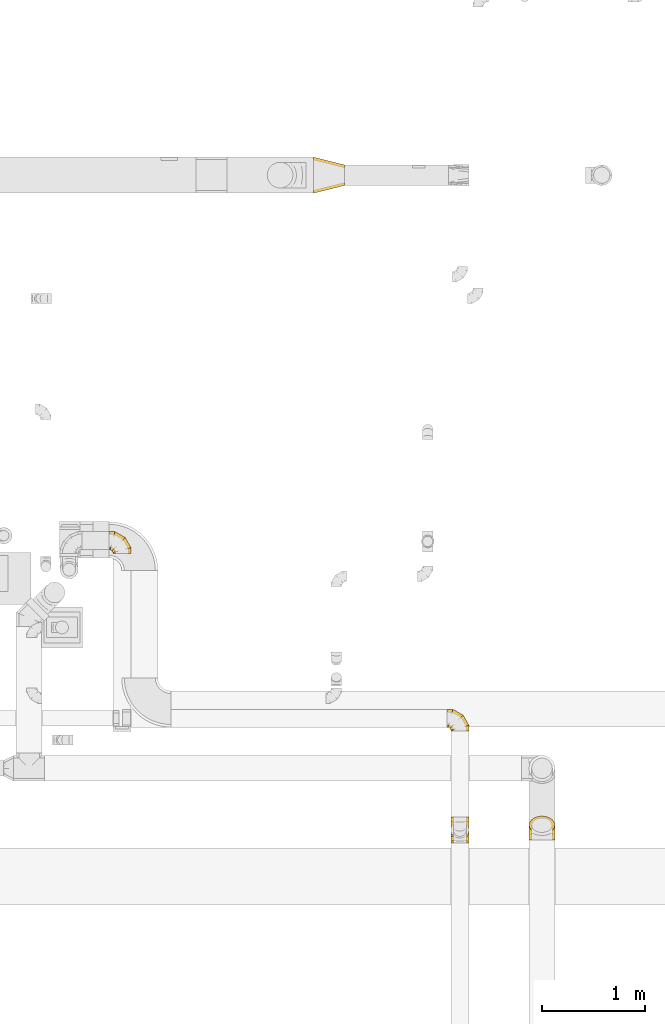
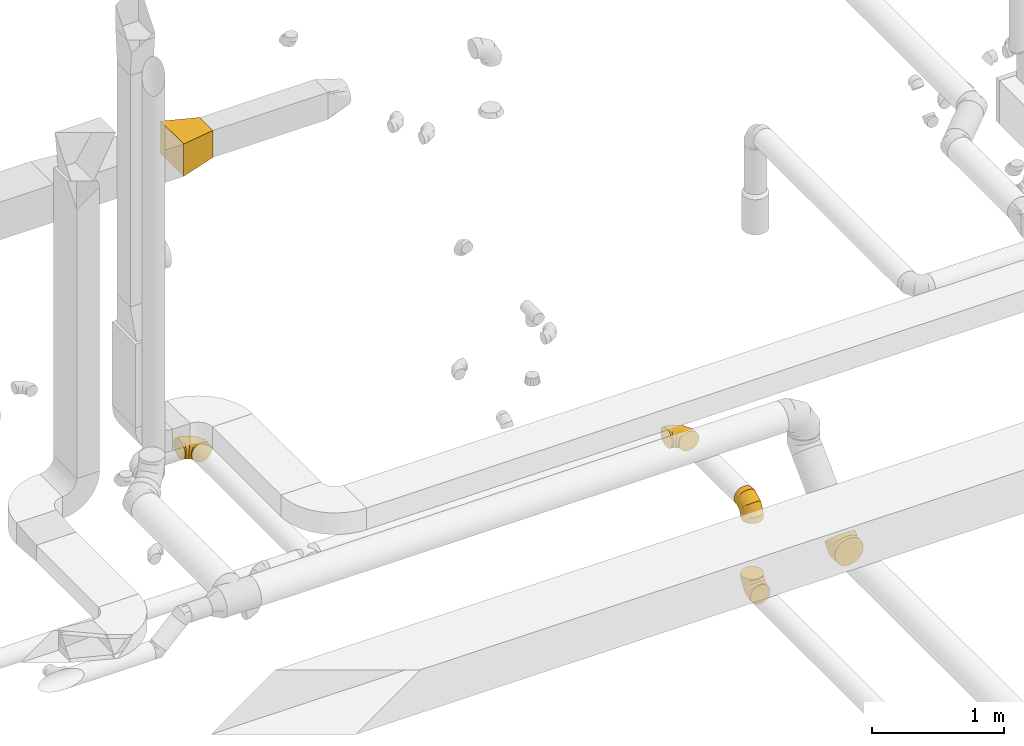
# One storey, part 24 of 97: 6 coverings.
"""IFC2X3 building model written with IfcOpenShell, lengths in millimetres."""

from ifc_helpers import new_model, entity, si_unit, converted_unit, derived_unit, direction, frame, origin, place, context, subcontext, project, spatial, faceted_brep, element, save


model = new_model("IFC2X3")

# Units and contexts
model_context = context("Model", 3, precision=0.01, world=origin(), true_north=direction((6.12303176911189e-17, 1.0)))
body_context = subcontext(model_context, "Body", "Model", "MODEL_VIEW")
ifc_project = project(units=[si_unit("LENGTHUNIT", "METRE", prefix="MILLI"), si_unit("AREAUNIT", "SQUARE_METRE"), si_unit("VOLUMEUNIT", "CUBIC_METRE"), converted_unit("PLANEANGLEUNIT", "DEGREE", entity("IfcRatioMeasure", 0.0174532925199433), si_unit("PLANEANGLEUNIT", "RADIAN"), dimensions=[0, 0, 0, 0, 0, 0, 0]), si_unit("MASSUNIT", "GRAM", prefix="KILO"), derived_unit("MASSDENSITYUNIT", [(si_unit("MASSUNIT", "GRAM", prefix="KILO"), 1), (si_unit("LENGTHUNIT", "METRE"), -3)]), derived_unit("MOMENTOFINERTIAUNIT", [(si_unit("LENGTHUNIT", "METRE"), 4)]), si_unit("TIMEUNIT", "SECOND"), si_unit("FREQUENCYUNIT", "HERTZ"), si_unit("THERMODYNAMICTEMPERATUREUNIT", "DEGREE_CELSIUS"), derived_unit("THERMALTRANSMITTANCEUNIT", [(si_unit("MASSUNIT", "GRAM", prefix="KILO"), 1), (si_unit("THERMODYNAMICTEMPERATUREUNIT", "KELVIN"), -1), (si_unit("TIMEUNIT", "SECOND"), -3)]), derived_unit("VOLUMETRICFLOWRATEUNIT", [(si_unit("LENGTHUNIT", "METRE"), 3), (si_unit("TIMEUNIT", "SECOND"), -1)]), derived_unit("MASSFLOWRATEUNIT", [(si_unit("MASSUNIT", "GRAM", prefix="KILO"), 1), (si_unit("TIMEUNIT", "SECOND"), -1)]), derived_unit("ROTATIONALFREQUENCYUNIT", [(si_unit("TIMEUNIT", "SECOND"), -1)]), si_unit("ELECTRICCURRENTUNIT", "AMPERE"), si_unit("ELECTRICVOLTAGEUNIT", "VOLT"), si_unit("POWERUNIT", "WATT"), si_unit("FORCEUNIT", "NEWTON", prefix="KILO"), si_unit("ILLUMINANCEUNIT", "LUX"), si_unit("LUMINOUSFLUXUNIT", "LUMEN"), si_unit("LUMINOUSINTENSITYUNIT", "CANDELA"), derived_unit("USERDEFINED", [(si_unit("MASSUNIT", "GRAM", prefix="KILO"), -1), (si_unit("LENGTHUNIT", "METRE"), -2), (si_unit("TIMEUNIT", "SECOND"), 3), (si_unit("LUMINOUSFLUXUNIT", "LUMEN"), 1)]), derived_unit("LINEARVELOCITYUNIT", [(si_unit("LENGTHUNIT", "METRE"), 1), (si_unit("TIMEUNIT", "SECOND"), -1)]), si_unit("PRESSUREUNIT", "PASCAL"), derived_unit("USERDEFINED", [(si_unit("LENGTHUNIT", "METRE"), -2), (si_unit("MASSUNIT", "GRAM", prefix="KILO"), 1), (si_unit("TIMEUNIT", "SECOND"), -2)]), derived_unit("LINEARFORCEUNIT", [(si_unit("MASSUNIT", "GRAM", prefix="KILO"), 1), (si_unit("LENGTHUNIT", "METRE"), 1), (si_unit("TIMEUNIT", "SECOND"), -2), (si_unit("LENGTHUNIT", "METRE"), -1)]), derived_unit("PLANARFORCEUNIT", [(si_unit("MASSUNIT", "GRAM", prefix="KILO"), 1), (si_unit("LENGTHUNIT", "METRE"), 1), (si_unit("TIMEUNIT", "SECOND"), -2), (si_unit("LENGTHUNIT", "METRE"), -2)])], contexts=[model_context])

# Site, building, storey
site_placement = place(None, origin())
site = spatial("IfcSite", under=ifc_project, at=site_placement, CompositionType="ELEMENT")
building_placement = place(site_placement, origin())
building = spatial("IfcBuilding", under=site, at=building_placement, CompositionType="ELEMENT")
storey_placement = place(building_placement, frame((0.0, 0.0, -4900.0)))
storey = spatial("IfcBuildingStorey", under=building, at=storey_placement, CompositionType="ELEMENT", Elevation=-4900.0)

# Coverings
covering_1_placement = place(storey_placement, frame((59937.65, 11680.87, 4025.9)))
element("IfcCovering", 1, at=covering_1_placement, inside=storey, PredefinedType="INSULATION", context=body_context, shape_type="Brep", body=[
    faceted_brep([(0.0, 97.96, 172.31), (0.0, 125.0, 176.6), (0.0, 152.04, 172.31), (0.0, 176.43, 159.88), (0.0, 195.79, 140.53), (0.0, 208.22, 116.13), (0.0, 212.5, 89.1), (0.0, 208.22, 62.06), (0.0, 195.79, 37.66), (0.0, 176.43, 18.31), (0.0, 152.04, 5.88), (0.0, 125.0, 1.6), (0.0, 97.96, 5.88), (0.0, 73.57, 18.31), (0.0, 54.21, 37.66), (0.0, 48.0, 49.86), (0.0, 41.78, 62.06), (0.0, 39.64, 75.58), (0.0, 37.5, 89.1), (0.0, 39.64, 102.61), (0.0, 41.78, 116.13), (0.0, 48.0, 128.33), (0.0, 54.21, 140.53), (0.0, 73.57, 159.88), (200.78, 0.0, 45.35), (209.52, 0.0, 66.45), (212.5, 0.0, 89.1), (209.52, 0.0, 111.74), (200.78, 0.0, 132.85), (186.87, 0.0, 150.97), (168.75, 0.0, 164.87), (147.65, 0.0, 173.61), (125.0, 0.0, 176.6), (102.35, 0.0, 173.61), (81.25, 0.0, 164.87), (63.13, 0.0, 150.97), (49.22, 0.0, 132.85), (40.48, 0.0, 111.74), (37.5, 0.0, 89.1), (40.48, 0.0, 66.45), (49.22, 0.0, 45.35), (63.13, 0.0, 27.22), (81.25, 0.0, 13.32), (102.35, 0.0, 4.58), (125.0, 0.0, 1.6), (147.65, 0.0, 4.58), (168.75, 0.0, 13.32), (186.87, 0.0, 27.22), (212.5, 56.94, 89.1), (209.52, 56.14, 111.74), (200.78, 53.8, 132.85), (186.87, 50.07, 150.97), (168.75, 45.22, 164.87), (147.65, 39.56, 173.61), (125.0, 33.49, 176.6), (102.35, 27.43, 173.61), (81.25, 21.77, 164.87), (63.13, 16.92, 150.97), (49.22, 13.19, 132.85), (40.48, 10.85, 111.74), (37.5, 10.05, 89.1), (40.48, 10.85, 66.45), (49.22, 13.19, 45.35), (63.13, 16.92, 27.22), (102.35, 27.43, 4.58), (125.0, 33.49, 1.6), (81.25, 21.77, 13.32), (147.65, 39.56, 4.58), (168.75, 45.22, 13.32), (186.87, 50.07, 27.22), (200.78, 53.8, 45.35), (209.52, 56.14, 66.45), (155.56, 155.56, 89.1), (153.38, 153.38, 111.74), (146.98, 146.98, 132.85), (136.8, 136.8, 150.97), (123.53, 123.53, 164.87), (108.08, 108.08, 173.61), (91.51, 91.51, 176.6), (74.93, 74.93, 173.61), (59.48, 59.48, 164.87), (46.21, 46.21, 150.97), (36.03, 36.03, 132.85), (29.63, 29.63, 111.74), (27.45, 27.45, 89.1), (29.63, 29.63, 66.45), (36.03, 36.03, 45.35), (46.21, 46.21, 27.22), (74.93, 74.93, 4.58), (91.51, 91.51, 1.6), (59.48, 59.48, 13.32), (108.08, 108.08, 4.58), (123.53, 123.53, 13.32), (136.8, 136.8, 27.22), (146.98, 146.98, 45.35), (153.38, 153.38, 66.45), (56.94, 212.5, 89.1), (56.14, 209.52, 111.74), (53.8, 200.78, 132.85), (50.07, 186.87, 150.97), (45.22, 168.75, 164.87), (39.56, 147.65, 173.61), (33.49, 125.0, 176.6), (27.43, 102.35, 173.61), (21.77, 81.25, 164.87), (16.92, 63.13, 150.97), (13.19, 49.22, 132.85), (10.85, 40.48, 111.74), (10.45, 38.99, 100.42), (10.05, 37.5, 89.1), (10.85, 40.48, 66.45), (13.19, 49.22, 45.35), (10.45, 38.99, 77.77), (16.92, 63.13, 27.22), (27.43, 102.35, 4.58), (33.49, 125.0, 1.6), (21.77, 81.25, 13.32), (39.56, 147.65, 4.58), (45.22, 168.75, 13.32), (50.07, 186.87, 27.22), (53.8, 200.78, 45.35), (56.14, 209.52, 66.45)], [[[0, 1, 2, 3, 4, 5, 6, 7, 8, 9, 10, 11, 12, 13, 14, 15, 16, 17, 18, 19, 20, 21, 22, 23]], [[24, 25, 26, 27, 28, 29, 30, 31, 32, 33, 34, 35, 36, 37, 38, 39, 40, 41, 42, 43, 44, 45, 46, 47]], [[26, 48, 49, 27]], [[27, 49, 50, 28]], [[28, 50, 51, 29]], [[30, 52, 53, 31]], [[31, 53, 54, 32]], [[29, 51, 52, 30]], [[55, 56, 34, 33]], [[54, 55, 33, 32]], [[57, 35, 34, 56]], [[58, 59, 37, 36]], [[58, 36, 35, 57]], [[60, 38, 37, 59]], [[61, 62, 40, 39]], [[60, 61, 39, 38]], [[41, 40, 62, 63]], [[64, 65, 44, 43]], [[66, 64, 43, 42]], [[63, 66, 42, 41]], [[46, 45, 67, 68]], [[47, 46, 68, 69]], [[44, 65, 67, 45]], [[25, 24, 70, 71]], [[26, 25, 71, 48]], [[69, 70, 24, 47]], [[49, 48, 72, 73]], [[50, 49, 73, 74]], [[74, 75, 51, 50]], [[52, 51, 75, 76]], [[53, 52, 76, 77]], [[54, 53, 77, 78]], [[79, 80, 56, 55]], [[78, 79, 55, 54]], [[57, 56, 80, 81]], [[82, 83, 59, 58]], [[81, 82, 58, 57]], [[60, 59, 83, 84]], [[85, 86, 62, 61]], [[84, 85, 61, 60]], [[63, 62, 86, 87]], [[88, 89, 65, 64]], [[90, 88, 64, 66]], [[87, 90, 66, 63]], [[67, 65, 89, 91]], [[68, 67, 91, 92]], [[69, 68, 92, 93]], [[71, 70, 94, 95]], [[48, 71, 95, 72]], [[93, 94, 70, 69]], [[73, 72, 96, 97]], [[74, 73, 97, 98]], [[98, 99, 75, 74]], [[76, 75, 99, 100]], [[77, 76, 100, 101]], [[78, 77, 101, 102]], [[103, 104, 80, 79]], [[102, 103, 79, 78]], [[81, 80, 104, 105]], [[106, 107, 83, 82]], [[105, 106, 82, 81]], [[84, 83, 107, 108, 109]], [[110, 111, 86, 85]], [[85, 84, 109, 112, 110]], [[87, 86, 111, 113]], [[114, 115, 89, 88]], [[116, 114, 88, 90]], [[113, 116, 90, 87]], [[91, 89, 115, 117]], [[92, 91, 117, 118]], [[93, 92, 118, 119]], [[95, 94, 120, 121]], [[72, 95, 121, 96]], [[119, 120, 94, 93]], [[97, 6, 5]], [[98, 5, 4]], [[6, 97, 96]], [[97, 5, 98]], [[4, 99, 98]], [[100, 3, 2]], [[101, 2, 1]], [[99, 3, 100]], [[100, 2, 101]], [[1, 102, 101]], [[3, 99, 4]], [[103, 1, 0]], [[104, 0, 23]], [[103, 102, 1]], [[104, 103, 0]], [[23, 105, 104]], [[21, 20, 107]], [[18, 109, 108]], [[107, 20, 19]], [[106, 105, 22]], [[106, 22, 21]], [[107, 19, 108]], [[21, 107, 106]], [[18, 108, 19]], [[22, 105, 23]], [[110, 17, 16]], [[111, 15, 14]], [[18, 112, 109]], [[18, 17, 112]], [[110, 16, 15]], [[110, 15, 111]], [[14, 113, 111]], [[116, 13, 12]], [[114, 12, 11]], [[116, 113, 13]], [[115, 114, 11]], [[116, 12, 114]], [[17, 110, 112]], [[13, 113, 14]], [[117, 11, 10]], [[118, 10, 9]], [[11, 117, 115]], [[117, 10, 118]], [[9, 119, 118]], [[120, 8, 7]], [[121, 7, 6]], [[119, 8, 120]], [[121, 120, 7]], [[96, 121, 6]], [[8, 119, 9]]]),
])
covering_2_placement = place(storey_placement, frame((63249.01, 8911.97, 3990.0)))
element("IfcCovering", 2, at=covering_2_placement, inside=storey, PredefinedType="INSULATION", context=body_context, shape_type="Brep", body=[
    faceted_brep([(172.31, 116.13, 0.0), (176.6, 89.1, 0.0), (172.31, 62.06, 0.0), (159.88, 37.66, 0.0), (140.53, 18.31, 0.0), (116.13, 5.88, 0.0), (89.1, 1.6, 0.0), (62.06, 5.88, 0.0), (37.66, 18.31, 0.0), (18.31, 37.66, 0.0), (5.88, 62.06, 0.0), (1.6, 89.1, 0.0), (5.88, 116.13, 0.0), (18.31, 140.53, 0.0), (37.66, 159.88, 0.0), (49.86, 166.1, 0.0), (62.06, 172.31, 0.0), (75.58, 174.45, 0.0), (89.1, 176.6, 0.0), (102.61, 174.45, 0.0), (116.13, 172.31, 0.0), (128.33, 166.1, 0.0), (140.53, 159.88, 0.0), (159.88, 140.53, 0.0), (45.35, 214.1, 200.78), (66.45, 214.1, 209.52), (89.1, 214.1, 212.5), (111.74, 214.1, 209.52), (132.85, 214.1, 200.78), (150.97, 214.1, 186.87), (164.87, 214.1, 168.75), (173.61, 214.1, 147.65), (176.6, 214.1, 125.0), (173.61, 214.1, 102.35), (164.87, 214.1, 81.25), (150.97, 214.1, 63.13), (132.85, 214.1, 49.22), (111.74, 214.1, 40.48), (89.1, 214.1, 37.5), (66.45, 214.1, 40.48), (45.35, 214.1, 49.22), (27.22, 214.1, 63.13), (13.32, 214.1, 81.25), (4.58, 214.1, 102.35), (1.6, 214.1, 125.0), (4.58, 214.1, 147.65), (13.32, 214.1, 168.75), (27.22, 214.1, 186.87), (89.1, 157.16, 212.5), (111.74, 157.95, 209.52), (132.85, 160.3, 200.78), (150.97, 164.02, 186.87), (164.87, 168.88, 168.75), (173.61, 174.53, 147.65), (176.6, 180.6, 125.0), (173.61, 186.67, 102.35), (164.87, 192.32, 81.25), (150.97, 197.18, 63.13), (132.85, 200.91, 49.22), (111.74, 203.25, 40.48), (89.1, 204.05, 37.5), (66.45, 203.25, 40.48), (45.35, 200.91, 49.22), (27.22, 197.18, 63.13), (4.58, 186.67, 102.35), (1.6, 180.6, 125.0), (13.32, 192.32, 81.25), (4.58, 174.53, 147.65), (13.32, 168.88, 168.75), (27.22, 164.02, 186.87), (45.35, 160.3, 200.78), (66.45, 157.95, 209.52), (89.1, 58.53, 155.56), (111.74, 60.72, 153.38), (132.85, 67.12, 146.98), (150.97, 77.3, 136.8), (164.87, 90.56, 123.53), (173.61, 106.01, 108.08), (176.6, 122.59, 91.51), (173.61, 139.17, 74.93), (164.87, 154.62, 59.48), (150.97, 167.88, 46.21), (132.85, 178.06, 36.03), (111.74, 184.46, 29.63), (89.1, 186.64, 27.45), (66.45, 184.46, 29.63), (45.35, 178.06, 36.03), (27.22, 167.88, 46.21), (4.58, 139.17, 74.93), (1.6, 122.59, 91.51), (13.32, 154.62, 59.48), (4.58, 106.01, 108.08), (13.32, 90.56, 123.53), (27.22, 77.3, 136.8), (45.35, 67.12, 146.98), (66.45, 60.72, 153.38), (89.1, 1.6, 56.94), (111.74, 4.58, 56.14), (132.85, 13.32, 53.8), (150.97, 27.22, 50.07), (164.87, 45.35, 45.22), (173.61, 66.45, 39.56), (176.6, 89.1, 33.49), (173.61, 111.74, 27.43), (164.87, 132.85, 21.77), (150.97, 150.97, 16.92), (132.85, 164.87, 13.19), (111.74, 173.61, 10.85), (100.42, 175.1, 10.45), (89.1, 176.6, 10.05), (66.45, 173.61, 10.85), (45.35, 164.87, 13.19), (77.77, 175.1, 10.45), (27.22, 150.97, 16.92), (4.58, 111.74, 27.43), (1.6, 89.1, 33.49), (13.32, 132.85, 21.77), (4.58, 66.45, 39.56), (13.32, 45.35, 45.22), (27.22, 27.22, 50.07), (45.35, 13.32, 53.8), (66.45, 4.58, 56.14)], [[[0, 1, 2, 3, 4, 5, 6, 7, 8, 9, 10, 11, 12, 13, 14, 15, 16, 17, 18, 19, 20, 21, 22, 23]], [[24, 25, 26, 27, 28, 29, 30, 31, 32, 33, 34, 35, 36, 37, 38, 39, 40, 41, 42, 43, 44, 45, 46, 47]], [[26, 48, 49, 27]], [[27, 49, 50, 28]], [[28, 50, 51, 29]], [[30, 52, 53, 31]], [[31, 53, 54, 32]], [[29, 51, 52, 30]], [[55, 56, 34, 33]], [[54, 55, 33, 32]], [[57, 35, 34, 56]], [[58, 59, 37, 36]], [[58, 36, 35, 57]], [[60, 38, 37, 59]], [[61, 62, 40, 39]], [[60, 61, 39, 38]], [[41, 40, 62, 63]], [[64, 65, 44, 43]], [[66, 64, 43, 42]], [[63, 66, 42, 41]], [[46, 45, 67, 68]], [[47, 46, 68, 69]], [[44, 65, 67, 45]], [[25, 24, 70, 71]], [[26, 25, 71, 48]], [[69, 70, 24, 47]], [[49, 48, 72, 73]], [[50, 49, 73, 74]], [[74, 75, 51, 50]], [[52, 51, 75, 76]], [[53, 52, 76, 77]], [[54, 53, 77, 78]], [[79, 80, 56, 55]], [[78, 79, 55, 54]], [[57, 56, 80, 81]], [[82, 83, 59, 58]], [[81, 82, 58, 57]], [[60, 59, 83, 84]], [[85, 86, 62, 61]], [[84, 85, 61, 60]], [[63, 62, 86, 87]], [[88, 89, 65, 64]], [[90, 88, 64, 66]], [[87, 90, 66, 63]], [[67, 65, 89, 91]], [[68, 67, 91, 92]], [[69, 68, 92, 93]], [[71, 70, 94, 95]], [[48, 71, 95, 72]], [[93, 94, 70, 69]], [[73, 72, 96, 97]], [[74, 73, 97, 98]], [[98, 99, 75, 74]], [[76, 75, 99, 100]], [[77, 76, 100, 101]], [[78, 77, 101, 102]], [[103, 104, 80, 79]], [[102, 103, 79, 78]], [[81, 80, 104, 105]], [[106, 107, 83, 82]], [[105, 106, 82, 81]], [[84, 83, 107, 108, 109]], [[110, 111, 86, 85]], [[85, 84, 109, 112, 110]], [[87, 86, 111, 113]], [[114, 115, 89, 88]], [[116, 114, 88, 90]], [[113, 116, 90, 87]], [[91, 89, 115, 117]], [[92, 91, 117, 118]], [[93, 92, 118, 119]], [[95, 94, 120, 121]], [[72, 95, 121, 96]], [[119, 120, 94, 93]], [[97, 6, 5]], [[98, 5, 4]], [[6, 97, 96]], [[97, 5, 98]], [[4, 99, 98]], [[100, 3, 2]], [[101, 2, 1]], [[99, 3, 100]], [[100, 2, 101]], [[1, 102, 101]], [[3, 99, 4]], [[103, 1, 0]], [[104, 0, 23]], [[103, 102, 1]], [[104, 103, 0]], [[23, 105, 104]], [[21, 20, 107]], [[18, 109, 108]], [[107, 20, 19]], [[106, 105, 22]], [[106, 22, 21]], [[107, 19, 108]], [[21, 107, 106]], [[18, 108, 19]], [[22, 105, 23]], [[110, 17, 16]], [[111, 15, 14]], [[18, 112, 109]], [[18, 17, 112]], [[110, 16, 15]], [[110, 15, 111]], [[14, 113, 111]], [[116, 13, 12]], [[114, 12, 11]], [[116, 113, 13]], [[115, 114, 11]], [[116, 12, 114]], [[17, 110, 112]], [[13, 113, 14]], [[117, 11, 10]], [[118, 10, 9]], [[11, 117, 115]], [[117, 10, 118]], [[9, 119, 118]], [[120, 8, 7]], [[121, 7, 6]], [[119, 8, 120]], [[121, 120, 7]], [[96, 121, 6]], [[8, 119, 9]]]),
])
covering_3_placement = place(storey_placement, frame((63213.11, 9958.58, 4025.9)))
element("IfcCovering", 3, at=covering_3_placement, inside=storey, PredefinedType="INSULATION", context=body_context, shape_type="Brep", body=[
    faceted_brep([(0.0, 97.96, 172.31), (0.0, 125.0, 176.6), (0.0, 152.04, 172.31), (0.0, 176.43, 159.88), (0.0, 195.79, 140.53), (0.0, 208.22, 116.13), (0.0, 212.5, 89.1), (0.0, 208.22, 62.06), (0.0, 195.79, 37.66), (0.0, 176.43, 18.31), (0.0, 152.04, 5.88), (0.0, 125.0, 1.6), (0.0, 97.96, 5.88), (0.0, 73.57, 18.31), (0.0, 54.21, 37.66), (0.0, 48.0, 49.86), (0.0, 41.78, 62.06), (0.0, 39.64, 75.58), (0.0, 37.5, 89.1), (0.0, 39.64, 102.61), (0.0, 41.78, 116.13), (0.0, 48.0, 128.33), (0.0, 54.21, 140.53), (0.0, 73.57, 159.88), (200.78, 0.0, 45.35), (209.52, 0.0, 66.45), (212.5, 0.0, 89.1), (209.52, 0.0, 111.74), (200.78, 0.0, 132.85), (186.87, 0.0, 150.97), (168.75, 0.0, 164.87), (147.65, 0.0, 173.61), (125.0, 0.0, 176.6), (102.35, 0.0, 173.61), (81.25, 0.0, 164.87), (63.13, 0.0, 150.97), (49.22, 0.0, 132.85), (40.48, 0.0, 111.74), (37.5, 0.0, 89.1), (40.48, 0.0, 66.45), (49.22, 0.0, 45.35), (63.13, 0.0, 27.22), (81.25, 0.0, 13.32), (102.35, 0.0, 4.58), (125.0, 0.0, 1.6), (147.65, 0.0, 4.58), (168.75, 0.0, 13.32), (186.87, 0.0, 27.22), (212.5, 56.94, 89.1), (209.52, 56.14, 111.74), (200.78, 53.8, 132.85), (186.87, 50.07, 150.97), (168.75, 45.22, 164.87), (147.65, 39.56, 173.61), (125.0, 33.49, 176.6), (102.35, 27.43, 173.61), (81.25, 21.77, 164.87), (63.13, 16.92, 150.97), (49.22, 13.19, 132.85), (40.48, 10.85, 111.74), (37.5, 10.05, 89.1), (40.48, 10.85, 66.45), (49.22, 13.19, 45.35), (63.13, 16.92, 27.22), (102.35, 27.43, 4.58), (125.0, 33.49, 1.6), (81.25, 21.77, 13.32), (147.65, 39.56, 4.58), (168.75, 45.22, 13.32), (186.87, 50.07, 27.22), (200.78, 53.8, 45.35), (209.52, 56.14, 66.45), (155.56, 155.56, 89.1), (153.38, 153.38, 111.74), (146.98, 146.98, 132.85), (136.8, 136.8, 150.97), (123.53, 123.53, 164.87), (108.08, 108.08, 173.61), (91.51, 91.51, 176.6), (74.93, 74.93, 173.61), (59.48, 59.48, 164.87), (46.21, 46.21, 150.97), (36.03, 36.03, 132.85), (29.63, 29.63, 111.74), (27.45, 27.45, 89.1), (29.63, 29.63, 66.45), (36.03, 36.03, 45.35), (46.21, 46.21, 27.22), (74.93, 74.93, 4.58), (91.51, 91.51, 1.6), (59.48, 59.48, 13.32), (108.08, 108.08, 4.58), (123.53, 123.53, 13.32), (136.8, 136.8, 27.22), (146.98, 146.98, 45.35), (153.38, 153.38, 66.45), (56.94, 212.5, 89.1), (56.14, 209.52, 111.74), (53.8, 200.78, 132.85), (50.07, 186.87, 150.97), (45.22, 168.75, 164.87), (39.56, 147.65, 173.61), (33.49, 125.0, 176.6), (27.43, 102.35, 173.61), (21.77, 81.25, 164.87), (16.92, 63.13, 150.97), (13.19, 49.22, 132.85), (10.85, 40.48, 111.74), (10.45, 38.99, 100.42), (10.05, 37.5, 89.1), (10.85, 40.48, 66.45), (13.19, 49.22, 45.35), (10.45, 38.99, 77.77), (16.92, 63.13, 27.22), (27.43, 102.35, 4.58), (33.49, 125.0, 1.6), (21.77, 81.25, 13.32), (39.56, 147.65, 4.58), (45.22, 168.75, 13.32), (50.07, 186.87, 27.22), (53.8, 200.78, 45.35), (56.14, 209.52, 66.45)], [[[0, 1, 2, 3, 4, 5, 6, 7, 8, 9, 10, 11, 12, 13, 14, 15, 16, 17, 18, 19, 20, 21, 22, 23]], [[24, 25, 26, 27, 28, 29, 30, 31, 32, 33, 34, 35, 36, 37, 38, 39, 40, 41, 42, 43, 44, 45, 46, 47]], [[26, 48, 49, 27]], [[27, 49, 50, 28]], [[28, 50, 51, 29]], [[30, 52, 53, 31]], [[31, 53, 54, 32]], [[29, 51, 52, 30]], [[55, 56, 34, 33]], [[54, 55, 33, 32]], [[57, 35, 34, 56]], [[58, 59, 37, 36]], [[58, 36, 35, 57]], [[60, 38, 37, 59]], [[61, 62, 40, 39]], [[60, 61, 39, 38]], [[41, 40, 62, 63]], [[64, 65, 44, 43]], [[66, 64, 43, 42]], [[63, 66, 42, 41]], [[46, 45, 67, 68]], [[47, 46, 68, 69]], [[44, 65, 67, 45]], [[25, 24, 70, 71]], [[26, 25, 71, 48]], [[69, 70, 24, 47]], [[49, 48, 72, 73]], [[50, 49, 73, 74]], [[74, 75, 51, 50]], [[52, 51, 75, 76]], [[53, 52, 76, 77]], [[54, 53, 77, 78]], [[79, 80, 56, 55]], [[78, 79, 55, 54]], [[57, 56, 80, 81]], [[82, 83, 59, 58]], [[81, 82, 58, 57]], [[60, 59, 83, 84]], [[85, 86, 62, 61]], [[84, 85, 61, 60]], [[63, 62, 86, 87]], [[88, 89, 65, 64]], [[90, 88, 64, 66]], [[87, 90, 66, 63]], [[67, 65, 89, 91]], [[68, 67, 91, 92]], [[69, 68, 92, 93]], [[71, 70, 94, 95]], [[48, 71, 95, 72]], [[93, 94, 70, 69]], [[73, 72, 96, 97]], [[74, 73, 97, 98]], [[98, 99, 75, 74]], [[76, 75, 99, 100]], [[77, 76, 100, 101]], [[78, 77, 101, 102]], [[103, 104, 80, 79]], [[102, 103, 79, 78]], [[81, 80, 104, 105]], [[106, 107, 83, 82]], [[105, 106, 82, 81]], [[84, 83, 107, 108, 109]], [[110, 111, 86, 85]], [[85, 84, 109, 112, 110]], [[87, 86, 111, 113]], [[114, 115, 89, 88]], [[116, 114, 88, 90]], [[113, 116, 90, 87]], [[91, 89, 115, 117]], [[92, 91, 117, 118]], [[93, 92, 118, 119]], [[95, 94, 120, 121]], [[72, 95, 121, 96]], [[119, 120, 94, 93]], [[97, 6, 5]], [[98, 5, 4]], [[6, 97, 96]], [[97, 5, 98]], [[4, 99, 98]], [[100, 3, 2]], [[101, 2, 1]], [[99, 3, 100]], [[100, 2, 101]], [[1, 102, 101]], [[3, 99, 4]], [[103, 1, 0]], [[104, 0, 23]], [[103, 102, 1]], [[104, 103, 0]], [[23, 105, 104]], [[21, 20, 107]], [[18, 109, 108]], [[107, 20, 19]], [[106, 105, 22]], [[106, 22, 21]], [[107, 19, 108]], [[21, 107, 106]], [[18, 108, 19]], [[22, 105, 23]], [[110, 17, 16]], [[111, 15, 14]], [[18, 112, 109]], [[18, 17, 112]], [[110, 16, 15]], [[110, 15, 111]], [[14, 113, 111]], [[116, 13, 12]], [[114, 12, 11]], [[116, 113, 13]], [[115, 114, 11]], [[116, 12, 114]], [[17, 110, 112]], [[13, 113, 14]], [[117, 11, 10]], [[118, 10, 9]], [[11, 117, 115]], [[117, 10, 118]], [[9, 119, 118]], [[120, 8, 7]], [[121, 7, 6]], [[119, 8, 120]], [[121, 120, 7]], [[96, 121, 6]], [[8, 119, 9]]]),
])
covering_4_placement = place(storey_placement, frame((61920.37, 15173.96, 3900.0)))
element("IfcCovering", 4, at=covering_4_placement, inside=storey, PredefinedType="INSULATION", context=body_context, shape_type="Brep", body=[
    faceted_brep([(300.0, 75.0, 275.0), (300.0, 75.0, 25.0), (300.0, 275.0, 25.0), (300.0, 275.0, 275.0), (0.0, 0.0, 300.0), (0.0, 350.0, 300.0), (0.0, 350.0, 0.0), (0.0, 0.0, 0.0)], [[[0, 1, 2, 3]], [[4, 5, 6, 7]], [[4, 7, 1, 0]], [[7, 6, 2, 1]], [[6, 5, 3, 2]], [[5, 4, 0, 3]]]),
])
covering_5_placement = place(storey_placement, frame((63249.01, 8876.07, 3260.9)))
element("IfcCovering", 5, at=covering_5_placement, inside=storey, PredefinedType="INSULATION", context=body_context, shape_type="Brep", body=[
    faceted_brep([(5.88, 0.0, 116.13), (1.6, 0.0, 89.1), (5.88, 0.0, 62.06), (18.31, 0.0, 37.66), (37.66, 0.0, 18.31), (62.06, 0.0, 5.88), (89.1, 0.0, 1.6), (116.13, 0.0, 5.88), (140.53, 0.0, 18.31), (159.88, 0.0, 37.66), (172.31, 0.0, 62.06), (176.6, 0.0, 89.1), (172.31, 0.0, 116.13), (159.88, 0.0, 140.53), (140.53, 0.0, 159.88), (128.33, 0.0, 166.1), (116.13, 0.0, 172.31), (102.61, 0.0, 174.45), (89.1, 0.0, 176.6), (75.58, 0.0, 174.45), (62.06, 0.0, 172.31), (49.86, 0.0, 166.1), (37.66, 0.0, 159.88), (18.31, 0.0, 140.53), (132.85, 200.78, 214.1), (111.74, 209.52, 214.1), (89.1, 212.5, 214.1), (66.45, 209.52, 214.1), (45.35, 200.78, 214.1), (27.22, 186.87, 214.1), (13.32, 168.75, 214.1), (4.58, 147.65, 214.1), (1.6, 125.0, 214.1), (4.58, 102.35, 214.1), (13.32, 81.25, 214.1), (27.22, 63.13, 214.1), (45.35, 49.22, 214.1), (66.45, 40.48, 214.1), (89.1, 37.5, 214.1), (111.74, 40.48, 214.1), (132.85, 49.22, 214.1), (150.97, 63.13, 214.1), (164.87, 81.25, 214.1), (173.61, 102.35, 214.1), (176.6, 125.0, 214.1), (173.61, 147.65, 214.1), (164.87, 168.75, 214.1), (150.97, 186.87, 214.1), (89.1, 212.5, 157.16), (66.45, 209.52, 157.95), (45.35, 200.78, 160.3), (27.22, 186.87, 164.02), (13.32, 168.75, 168.88), (4.58, 147.65, 174.53), (1.6, 125.0, 180.6), (4.58, 102.35, 186.67), (13.32, 81.25, 192.32), (27.22, 63.13, 197.18), (45.35, 49.22, 200.91), (66.45, 40.48, 203.25), (89.1, 37.5, 204.05), (111.74, 40.48, 203.25), (132.85, 49.22, 200.91), (150.97, 63.13, 197.18), (173.61, 102.35, 186.67), (176.6, 125.0, 180.6), (164.87, 81.25, 192.32), (173.61, 147.65, 174.53), (164.87, 168.75, 168.88), (150.97, 186.87, 164.02), (132.85, 200.78, 160.3), (111.74, 209.52, 157.95), (89.1, 155.56, 58.53), (66.45, 153.38, 60.72), (45.35, 146.98, 67.12), (27.22, 136.8, 77.3), (13.32, 123.53, 90.56), (4.58, 108.08, 106.01), (1.6, 91.51, 122.59), (4.58, 74.93, 139.17), (13.32, 59.48, 154.62), (27.22, 46.21, 167.88), (45.35, 36.03, 178.06), (66.45, 29.63, 184.46), (89.1, 27.45, 186.64), (111.74, 29.63, 184.46), (132.85, 36.03, 178.06), (150.97, 46.21, 167.88), (173.61, 74.93, 139.17), (176.6, 91.51, 122.59), (164.87, 59.48, 154.62), (173.61, 108.08, 106.01), (164.87, 123.53, 90.56), (150.97, 136.8, 77.3), (132.85, 146.98, 67.12), (111.74, 153.38, 60.72), (89.1, 56.94, 1.6), (66.45, 56.14, 4.58), (45.35, 53.8, 13.32), (27.22, 50.07, 27.22), (13.32, 45.22, 45.35), (4.58, 39.56, 66.45), (1.6, 33.49, 89.1), (4.58, 27.43, 111.74), (13.32, 21.77, 132.85), (27.22, 16.92, 150.97), (45.35, 13.19, 164.87), (66.45, 10.85, 173.61), (77.77, 10.45, 175.1), (89.1, 10.05, 176.6), (111.74, 10.85, 173.61), (132.85, 13.19, 164.87), (100.42, 10.45, 175.1), (150.97, 16.92, 150.97), (173.61, 27.43, 111.74), (176.6, 33.49, 89.1), (164.87, 21.77, 132.85), (173.61, 39.56, 66.45), (164.87, 45.22, 45.35), (150.97, 50.07, 27.22), (132.85, 53.8, 13.32), (111.74, 56.14, 4.58)], [[[0, 1, 2, 3, 4, 5, 6, 7, 8, 9, 10, 11, 12, 13, 14, 15, 16, 17, 18, 19, 20, 21, 22, 23]], [[24, 25, 26, 27, 28, 29, 30, 31, 32, 33, 34, 35, 36, 37, 38, 39, 40, 41, 42, 43, 44, 45, 46, 47]], [[26, 48, 49, 27]], [[27, 49, 50, 28]], [[28, 50, 51, 29]], [[30, 52, 53, 31]], [[31, 53, 54, 32]], [[29, 51, 52, 30]], [[55, 56, 34, 33]], [[54, 55, 33, 32]], [[57, 35, 34, 56]], [[58, 59, 37, 36]], [[58, 36, 35, 57]], [[60, 38, 37, 59]], [[61, 62, 40, 39]], [[60, 61, 39, 38]], [[41, 40, 62, 63]], [[64, 65, 44, 43]], [[66, 64, 43, 42]], [[63, 66, 42, 41]], [[46, 45, 67, 68]], [[47, 46, 68, 69]], [[44, 65, 67, 45]], [[25, 24, 70, 71]], [[26, 25, 71, 48]], [[69, 70, 24, 47]], [[49, 48, 72, 73]], [[50, 49, 73, 74]], [[74, 75, 51, 50]], [[52, 51, 75, 76]], [[53, 52, 76, 77]], [[54, 53, 77, 78]], [[79, 80, 56, 55]], [[78, 79, 55, 54]], [[57, 56, 80, 81]], [[82, 83, 59, 58]], [[81, 82, 58, 57]], [[60, 59, 83, 84]], [[85, 86, 62, 61]], [[84, 85, 61, 60]], [[63, 62, 86, 87]], [[88, 89, 65, 64]], [[90, 88, 64, 66]], [[87, 90, 66, 63]], [[67, 65, 89, 91]], [[68, 67, 91, 92]], [[69, 68, 92, 93]], [[71, 70, 94, 95]], [[48, 71, 95, 72]], [[93, 94, 70, 69]], [[73, 72, 96, 97]], [[74, 73, 97, 98]], [[98, 99, 75, 74]], [[76, 75, 99, 100]], [[77, 76, 100, 101]], [[78, 77, 101, 102]], [[103, 104, 80, 79]], [[102, 103, 79, 78]], [[81, 80, 104, 105]], [[106, 107, 83, 82]], [[105, 106, 82, 81]], [[84, 83, 107, 108, 109]], [[110, 111, 86, 85]], [[85, 84, 109, 112, 110]], [[87, 86, 111, 113]], [[114, 115, 89, 88]], [[116, 114, 88, 90]], [[113, 116, 90, 87]], [[91, 89, 115, 117]], [[92, 91, 117, 118]], [[93, 92, 118, 119]], [[95, 94, 120, 121]], [[72, 95, 121, 96]], [[119, 120, 94, 93]], [[97, 6, 5]], [[98, 5, 4]], [[6, 97, 96]], [[97, 5, 98]], [[4, 99, 98]], [[100, 3, 2]], [[101, 2, 1]], [[99, 3, 100]], [[100, 2, 101]], [[1, 102, 101]], [[3, 99, 4]], [[103, 1, 0]], [[104, 0, 23]], [[103, 102, 1]], [[104, 103, 0]], [[23, 105, 104]], [[21, 20, 107]], [[18, 109, 108]], [[107, 20, 19]], [[106, 105, 22]], [[106, 22, 21]], [[107, 19, 108]], [[21, 107, 106]], [[18, 108, 19]], [[22, 105, 23]], [[110, 17, 16]], [[111, 15, 14]], [[18, 112, 109]], [[18, 17, 112]], [[110, 16, 15]], [[110, 15, 111]], [[14, 113, 111]], [[116, 13, 12]], [[114, 12, 11]], [[116, 113, 13]], [[115, 114, 11]], [[116, 12, 114]], [[17, 110, 112]], [[13, 113, 14]], [[117, 11, 10]], [[118, 10, 9]], [[11, 117, 115]], [[117, 10, 118]], [[9, 119, 118]], [[120, 8, 7]], [[121, 7, 6]], [[119, 8, 120]], [[121, 120, 7]], [[96, 121, 6]], [[8, 119, 9]]]),
])
covering_6_placement = place(storey_placement, frame((64007.19, 8906.14, 3323.4)))
element("IfcCovering", 6, at=covering_6_placement, inside=storey, PredefinedType="INSULATION", context=body_context, shape_type="Brep", body=[
    faceted_brep([(25.47, 89.47, 237.13), (53.12, 69.91, 256.68), (87.97, 57.36, 269.24), (126.6, 53.03, 273.56), (165.22, 57.36, 269.24), (200.07, 69.91, 256.68), (227.72, 89.47, 237.13), (245.48, 114.11, 212.49), (251.6, 141.42, 185.17), (245.48, 168.73, 157.86), (227.72, 193.37, 133.22), (200.07, 212.93, 113.67), (165.22, 225.48, 101.11), (126.6, 229.81, 96.79), (87.97, 225.48, 101.11), (53.12, 212.93, 113.67), (25.47, 193.37, 133.22), (7.71, 168.73, 157.86), (1.6, 141.42, 185.17), (7.71, 114.11, 212.49), (94.24, 0.0, 5.85), (126.6, 0.0, 1.6), (158.95, 0.0, 5.85), (189.1, 0.0, 18.34), (214.98, 0.0, 38.21), (234.85, 0.0, 64.1), (247.34, 0.0, 94.24), (251.6, 0.0, 126.6), (247.34, 0.0, 158.95), (234.85, 0.0, 189.1), (214.98, 0.0, 214.98), (189.1, 0.0, 234.85), (158.95, 0.0, 247.34), (126.6, 0.0, 251.6), (94.24, 0.0, 247.34), (64.1, 0.0, 234.85), (38.21, 0.0, 214.98), (18.34, 0.0, 189.1), (5.85, 0.0, 158.95), (1.6, 0.0, 126.6), (5.85, 0.0, 94.24), (18.34, 0.0, 64.1), (38.21, 0.0, 38.21), (64.1, 0.0, 18.34), (126.6, 134.62, 1.6), (158.95, 132.86, 5.85), (189.1, 127.68, 18.34), (214.98, 119.45, 38.21), (234.85, 108.73, 64.1), (247.34, 96.24, 94.24), (251.6, 82.84, 126.6), (247.34, 69.44, 158.95), (234.85, 56.95, 189.1), (214.98, 46.23, 214.98), (158.95, 32.83, 247.34), (126.6, 31.07, 251.6), (189.1, 38.0, 234.85), (64.1, 38.0, 234.85), (38.21, 46.23, 214.98), (94.24, 32.83, 247.34), (5.85, 69.44, 158.95), (1.6, 82.84, 126.6), (18.34, 56.95, 189.1), (5.85, 96.24, 94.24), (18.34, 108.73, 64.1), (38.21, 119.45, 38.21), (64.1, 127.68, 18.34), (94.24, 132.86, 5.85)], [[[0, 1, 2, 3, 4, 5, 6, 7, 8, 9, 10, 11, 12, 13, 14, 15, 16, 17, 18, 19]], [[20, 21, 22, 23, 24, 25, 26, 27, 28, 29, 30, 31, 32, 33, 34, 35, 36, 37, 38, 39, 40, 41, 42, 43]], [[21, 44, 45, 22]], [[22, 45, 46, 23]], [[47, 24, 23, 46]], [[24, 47, 48, 25]], [[25, 48, 49, 26]], [[50, 27, 26, 49]], [[51, 52, 29, 28]], [[50, 51, 28, 27]], [[29, 52, 53, 30]], [[54, 55, 33, 32]], [[56, 54, 32, 31]], [[30, 53, 56, 31]], [[35, 57, 58, 36]], [[59, 57, 35, 34]], [[33, 55, 59, 34]], [[60, 61, 39, 38]], [[62, 60, 38, 37]], [[58, 62, 37, 36]], [[40, 39, 61, 63]], [[41, 40, 63, 64]], [[64, 65, 42, 41]], [[20, 43, 66, 67]], [[21, 20, 67, 44]], [[65, 66, 43, 42]], [[12, 11, 46]], [[13, 12, 45]], [[13, 45, 44]], [[45, 12, 46]], [[11, 47, 46]], [[48, 10, 9]], [[49, 9, 8]], [[47, 10, 48]], [[48, 9, 49]], [[8, 50, 49]], [[10, 47, 11]], [[7, 6, 52]], [[8, 7, 51]], [[51, 50, 8]], [[52, 51, 7]], [[6, 53, 52]], [[56, 5, 4]], [[54, 4, 3]], [[56, 53, 5]], [[55, 54, 3]], [[56, 4, 54]], [[5, 53, 6]], [[2, 1, 57]], [[3, 2, 59]], [[59, 55, 3]], [[57, 59, 2]], [[1, 58, 57]], [[62, 0, 19]], [[60, 19, 18]], [[62, 58, 0]], [[61, 60, 18]], [[62, 19, 60]], [[0, 58, 1]], [[63, 18, 17]], [[64, 17, 16]], [[18, 63, 61]], [[63, 17, 64]], [[16, 65, 64]], [[66, 15, 14]], [[67, 14, 13]], [[65, 15, 66]], [[67, 66, 14]], [[44, 67, 13]], [[15, 65, 16]]]),
])

save(model, "model.ifc")
